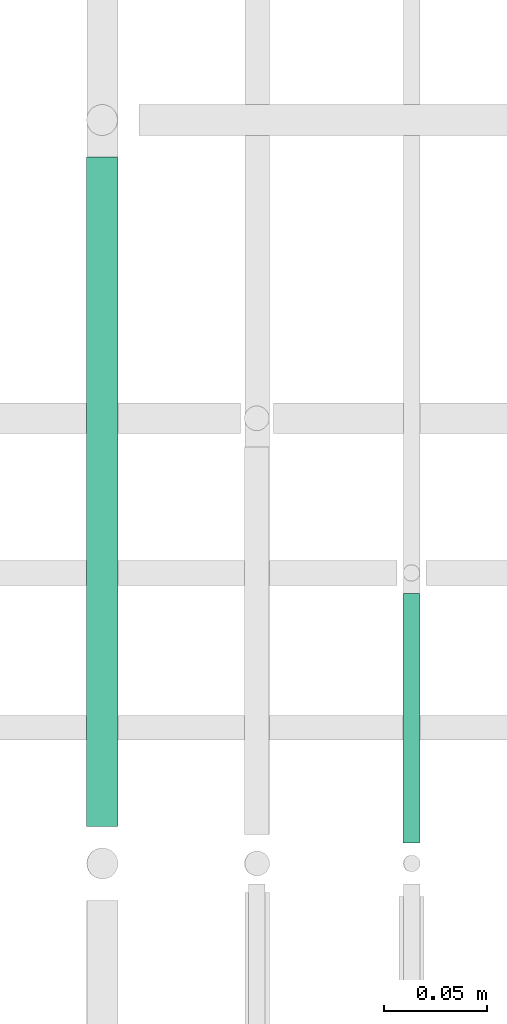
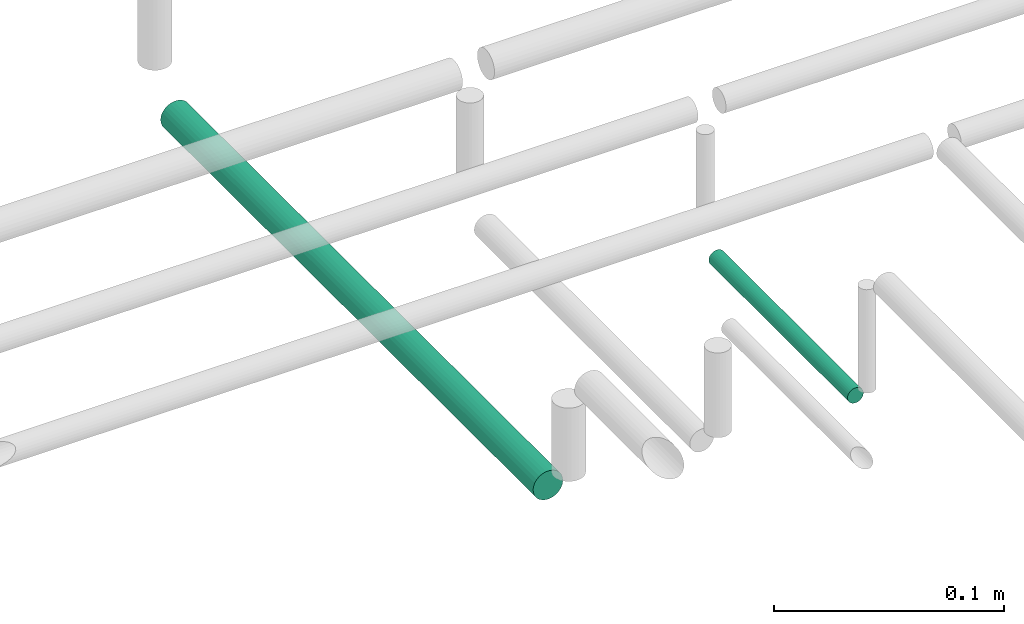
# One storey, part 130 of 331: 2 flow segments.
"""IFC2X3 building model written with IfcOpenShell, lengths in millimetres."""

from ifc_helpers import new_model, entity, si_unit, converted_unit, derived_unit, direction, frame, origin, origin_2d_with_axis, place, context, subcontext, project, spatial, circle, extrude, type_object, element, save


model = new_model("IFC2X3")

# Units and contexts
model_context = context("Model", 3, precision=0.01, world=origin(), true_north=direction((6.12303176911189e-17, 1.0)))
body_context = subcontext(model_context, "Body", "Model", "MODEL_VIEW")
ifc_project = project(units=[si_unit("LENGTHUNIT", "METRE", prefix="MILLI"), si_unit("AREAUNIT", "SQUARE_METRE"), si_unit("VOLUMEUNIT", "CUBIC_METRE"), converted_unit("PLANEANGLEUNIT", "DEGREE", entity("IfcRatioMeasure", 0.0174532925199433), si_unit("PLANEANGLEUNIT", "RADIAN"), dimensions=[0, 0, 0, 0, 0, 0, 0]), si_unit("MASSUNIT", "GRAM", prefix="KILO"), derived_unit("MASSDENSITYUNIT", [(si_unit("MASSUNIT", "GRAM", prefix="KILO"), 1), (si_unit("LENGTHUNIT", "METRE"), -3)]), derived_unit("MOMENTOFINERTIAUNIT", [(si_unit("LENGTHUNIT", "METRE"), 4)]), si_unit("TIMEUNIT", "SECOND"), si_unit("FREQUENCYUNIT", "HERTZ"), si_unit("THERMODYNAMICTEMPERATUREUNIT", "DEGREE_CELSIUS"), derived_unit("THERMALTRANSMITTANCEUNIT", [(si_unit("MASSUNIT", "GRAM", prefix="KILO"), 1), (si_unit("THERMODYNAMICTEMPERATUREUNIT", "KELVIN"), -1), (si_unit("TIMEUNIT", "SECOND"), -3)]), derived_unit("VOLUMETRICFLOWRATEUNIT", [(si_unit("LENGTHUNIT", "METRE"), 3), (si_unit("TIMEUNIT", "SECOND"), -1)]), derived_unit("MASSFLOWRATEUNIT", [(si_unit("MASSUNIT", "GRAM", prefix="KILO"), 1), (si_unit("TIMEUNIT", "SECOND"), -1)]), derived_unit("ROTATIONALFREQUENCYUNIT", [(si_unit("TIMEUNIT", "SECOND"), -1)]), si_unit("ELECTRICCURRENTUNIT", "AMPERE"), si_unit("ELECTRICVOLTAGEUNIT", "VOLT"), si_unit("POWERUNIT", "WATT"), si_unit("FORCEUNIT", "NEWTON", prefix="KILO"), si_unit("ILLUMINANCEUNIT", "LUX"), si_unit("LUMINOUSFLUXUNIT", "LUMEN"), si_unit("LUMINOUSINTENSITYUNIT", "CANDELA"), derived_unit("USERDEFINED", [(si_unit("MASSUNIT", "GRAM", prefix="KILO"), -1), (si_unit("LENGTHUNIT", "METRE"), -2), (si_unit("TIMEUNIT", "SECOND"), 3), (si_unit("LUMINOUSFLUXUNIT", "LUMEN"), 1)]), derived_unit("LINEARVELOCITYUNIT", [(si_unit("LENGTHUNIT", "METRE"), 1), (si_unit("TIMEUNIT", "SECOND"), -1)]), si_unit("PRESSUREUNIT", "PASCAL"), derived_unit("USERDEFINED", [(si_unit("LENGTHUNIT", "METRE"), -2), (si_unit("MASSUNIT", "GRAM", prefix="KILO"), 1), (si_unit("TIMEUNIT", "SECOND"), -2)]), derived_unit("LINEARFORCEUNIT", [(si_unit("MASSUNIT", "GRAM", prefix="KILO"), 1), (si_unit("LENGTHUNIT", "METRE"), 1), (si_unit("TIMEUNIT", "SECOND"), -2), (si_unit("LENGTHUNIT", "METRE"), -1)]), derived_unit("PLANARFORCEUNIT", [(si_unit("MASSUNIT", "GRAM", prefix="KILO"), 1), (si_unit("LENGTHUNIT", "METRE"), 1), (si_unit("TIMEUNIT", "SECOND"), -2), (si_unit("LENGTHUNIT", "METRE"), -2)])], contexts=[model_context])

# Site, building, storey
site_placement = place(None, frame((0.0, -0.00077364408347762, 0.0)))
site = spatial("IfcSite", under=ifc_project, at=site_placement, CompositionType="ELEMENT")
building_placement = place(site_placement, origin())
building = spatial("IfcBuilding", under=site, at=building_placement, CompositionType="ELEMENT")
storey_placement = place(building_placement, origin())
storey = spatial("IfcBuildingStorey", under=building, at=storey_placement, CompositionType="ELEMENT", Elevation=0.0)

# Flow segments
pipe_segment_type = type_object("IfcPipeSegmentType", PredefinedType="NOTDEFINED")
flow_segment_1_placement = place(storey_placement, frame((20765.5132627125, 8100.14880665487, 14469.404727873)))
element("IfcFlowSegment", 1, at=flow_segment_1_placement, inside=storey, type_object=pipe_segment_type, context=body_context, shape_type="SweptSolid", body=[
    extrude(circle(Radius=4.0, at=origin_2d_with_axis()), frame((5.59527223591499, 0.0, 5.59527223591499), z_axis=(0.0, 1.0, 0.0), x_axis=(1.0, 0.0, 0.0)), (0.0, 0.0, 1.0), 120.861137194476),
])
flow_segment_2_placement = place(storey_placement, frame((20612.0132627125, 8108.14880665488, 14465.904727873)))
element("IfcFlowSegment", 2, at=flow_segment_2_placement, inside=storey, type_object=pipe_segment_type, context=body_context, shape_type="SweptSolid", body=[
    extrude(circle(Radius=7.5, at=origin_2d_with_axis()), frame((9.09527223591419, 0.0, 9.09527223591636), z_axis=(0.0, 1.0, 0.0), x_axis=(-1.0, 0.0, 0.0)), (0.0, 0.0, 1.0), 324.471757172469),
])

save(model, "model.ifc")
